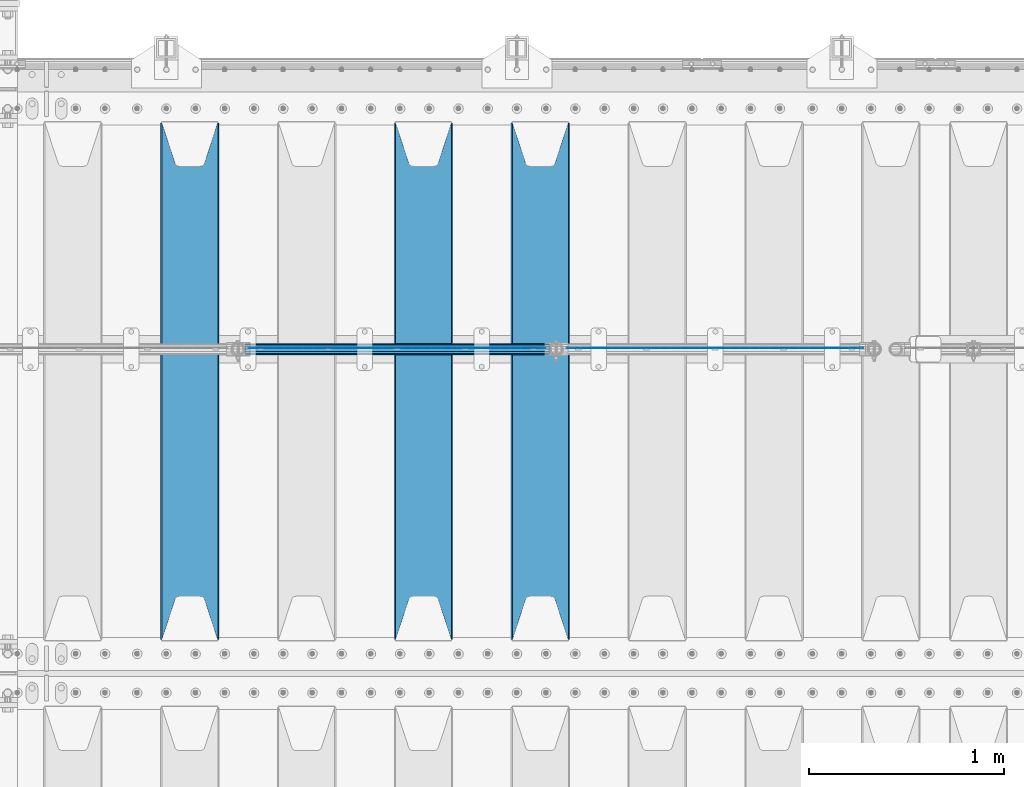
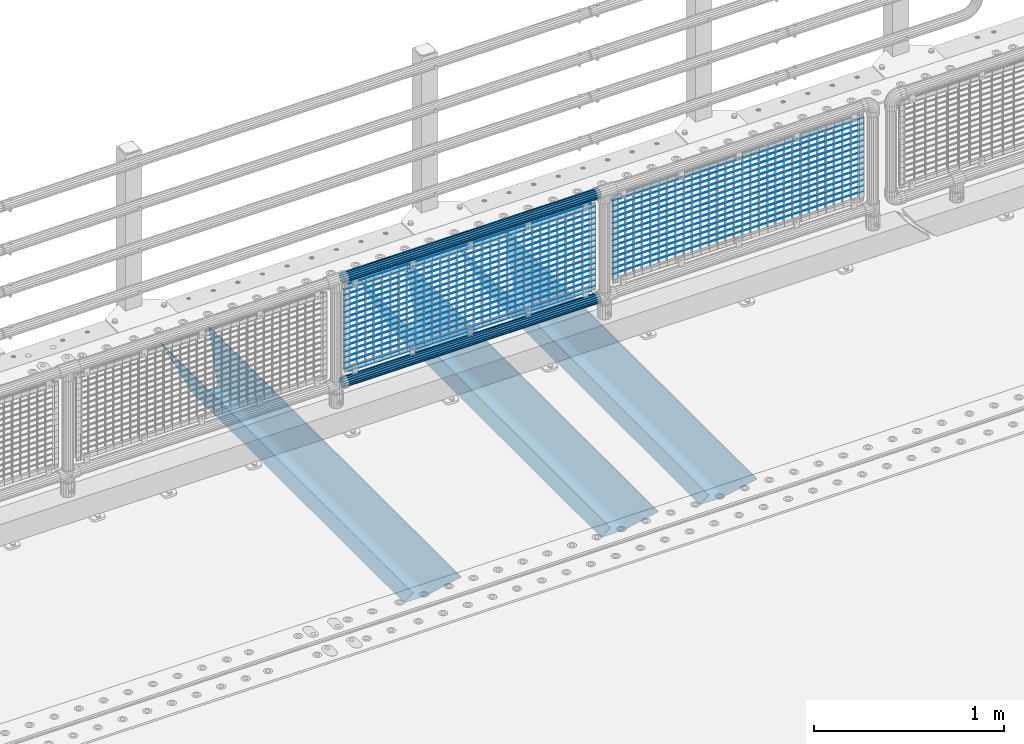
# One storey, part 133 of 242: 36 beams.
"""IFC2X3 building model written with IfcOpenShell, lengths in millimetres."""

from ifc_helpers import new_model, si_unit, frame, origin_with_axes, place, context, subcontext, project, spatial, faceted_brep, material, type_object, element, save


model = new_model("IFC2X3")

# Units and contexts
model_context = context("Model", 3, precision=1e-05, world=origin_with_axes())
body_context = subcontext(model_context, "Body", "Model", "MODEL_VIEW")
ifc_project = project(units=[si_unit("LENGTHUNIT", "METRE", prefix="MILLI"), si_unit("AREAUNIT", "SQUARE_METRE"), si_unit("VOLUMEUNIT", "CUBIC_METRE"), si_unit("MASSUNIT", "GRAM", prefix="KILO"), si_unit("TIMEUNIT", "SECOND"), si_unit("PLANEANGLEUNIT", "RADIAN"), si_unit("SOLIDANGLEUNIT", "STERADIAN"), si_unit("THERMODYNAMICTEMPERATUREUNIT", "DEGREE_CELSIUS"), si_unit("LUMINOUSINTENSITYUNIT", "LUMEN")], contexts=[model_context])

# Site, building, storey
site_placement = place(None, origin_with_axes())
site = spatial("IfcSite", under=ifc_project, at=site_placement, CompositionType="ELEMENT")
building_placement = place(site_placement, origin_with_axes())
building = spatial("IfcBuilding", under=site, at=building_placement, Name="Standard", CompositionType="ELEMENT")
storey_placement = place(building_placement, origin_with_axes())
storey = spatial("IfcBuildingStorey", under=building, at=storey_placement, Name="Undefined", CompositionType="ELEMENT", Elevation=0.0)

# Beams
ifc_material_1 = material(Name="Misc_Undefined")
beam_type_1 = type_object("IfcBeamType", Name="D3", PredefinedType="NOTDEFINED")
for number, where, z_axis, x_axis in (
    (1, (-25444.0, -19329.5, 851.596999999999), (0.0, 0.0, 1.0), (1.0, 0.0, 0.0)),
    (2, (-25444.0, -19329.5, 669.452), (0.0, 0.0, 1.0), (1.0, 0.0, 0.0)),
    (3, (-25444.0, -19329.5, 523.736), (0.0, 0.0, 1.0), (1.0, 0.0, 0.0)),
    (4, (-25444.0, -19329.5, 487.307), (0.0, 0.0, 1.0), (1.0, 0.0, 0.0)),
    (5, (-25444.0, -19329.5, 705.881), (0.0, 0.0, 1.0), (1.0, 0.0, 0.0)),
    (6, (-25444.0, -19329.5, 596.594), (0.0, 0.0, 1.0), (1.0, 0.0, 0.0)),
    (7, (-25444.0, -19329.5, 450.878), (0.0, 0.0, 1.0), (1.0, 0.0, 0.0)),
    (8, (-25444.0, -19329.5, 815.167999999999), (0.0, 0.0, 1.0), (1.0, 0.0, 0.0)),
    (9, (-25444.0, -19329.5, 888.025999999999), (0.0, 0.0, 1.0), (1.0, 0.0, 0.0)),
    (10, (-25444.0, -19329.5, 778.738999999999), (0.0, 0.0, 1.0), (1.0, 0.0, 0.0)),
    (11, (-25444.0, -19329.5, 742.309999999999), (0.0, 0.0, 1.0), (1.0, 0.0, 0.0)),
    (12, (-25444.0, -19329.5, 633.023), (0.0, 0.0, 1.0), (1.0, 0.0, 0.0)),
    (13, (-25444.0, -19329.5, 560.165), (0.0, 0.0, 1.0), (1.0, 0.0, 0.0)),
    (14, (-25444.0, -19329.5, 414.449), (0.0, 0.0, 1.0), (1.0, 0.0, 0.0)),
    (15, (-27077.0, -19329.5, 851.596999999999), (0.0, 0.0, 1.0), (1.0, 0.0, 0.0)),
    (16, (-27077.0, -19329.5, 669.452), (0.0, 0.0, 1.0), (1.0, 0.0, 0.0)),
    (17, (-27077.0, -19329.5, 523.736), (0.0, 0.0, 1.0), (1.0, 0.0, 0.0)),
    (18, (-27077.0, -19329.5, 487.307), (0.0, 0.0, 1.0), (1.0, 0.0, 0.0)),
    (19, (-27077.0, -19329.5, 705.881), (0.0, 0.0, 1.0), (1.0, 0.0, 0.0)),
    (20, (-27077.0, -19329.5, 596.594), (0.0, 0.0, 1.0), (1.0, 0.0, 0.0)),
    (21, (-27077.0, -19329.5, 450.878), (0.0, 0.0, 1.0), (1.0, 0.0, 0.0)),
    (22, (-27077.0, -19329.5, 815.167999999999), (0.0, 0.0, 1.0), (1.0, 0.0, 0.0)),
    (23, (-27077.0, -19329.5, 888.025999999999), (0.0, 0.0, 1.0), (1.0, 0.0, 0.0)),
    (24, (-27077.0, -19329.5, 778.738999999999), (0.0, 0.0, 1.0), (1.0, 0.0, 0.0)),
    (25, (-27077.0, -19329.5, 742.309999999999), (0.0, 0.0, 1.0), (1.0, 0.0, 0.0)),
    (26, (-27077.0, -19329.5, 633.023), (0.0, 0.0, 1.0), (1.0, 0.0, 0.0)),
    (27, (-27077.0, -19329.5, 560.165), (0.0, 0.0, 1.0), (1.0, 0.0, 0.0)),
    (28, (-27077.0, -19329.5, 414.449), (0.0, 0.0, 1.0), (1.0, 0.0, 0.0)),
):
    element("IfcBeam", number, at=place(storey_placement, frame(where, z_axis=z_axis, x_axis=x_axis)), inside=storey, type_object=beam_type_1, material=ifc_material_1, ObjectType="D3", context=body_context, shape_type="Brep", body=[
        faceted_brep([(0.0, -1.50000000000364, 0.0), (-3.63797880709171e-12, -0.750000000003638, -1.29903810567669), (1523.0, -0.75, -1.29903810567669), (1523.0, -1.5, 0.0), (0.0, 0.749999999996362, -1.29903810567669), (1523.0, 0.75, -1.29903810567669), (-3.63797880709171e-12, 1.49999999999636, 0.0), (1523.0, 1.5, 0.0), (0.0, 0.749999999996362, 1.29903810567669), (1523.0, 0.75, 1.29903810567669), (-3.63797880709171e-12, -0.750000000003638, 1.29903810567669), (1523.0, -0.75, 1.29903810567669)], [[[0, 1, 2, 3]], [[1, 4, 5, 2]], [[4, 6, 7, 5]], [[6, 8, 9, 7]], [[8, 10, 11, 9]], [[10, 0, 3, 11]], [[5, 7, 9, 11, 3, 2]], [[10, 8, 6, 4, 1, 0]]]),
    ])
beam_1_placement = place(storey_placement, frame((-27052.0, -19329.5, 353.02), z_axis=(0.0, 0.0, 1.0), x_axis=(1.0, 0.0, 0.0)))
element("IfcBeam", 29, at=beam_1_placement, inside=storey, type_object=beam_type_1, material=ifc_material_1, ObjectType="D3", context=body_context, shape_type="Brep", body=[
    faceted_brep([(0.0, -1.50000000000364, 0.0), (-3.63797880709171e-12, -0.750000000003638, -1.29903810567669), (1473.0, -0.75, -1.29903810567669), (1473.0, -1.5, 0.0), (0.0, 0.749999999996362, -1.29903810567669), (1473.0, 0.75, -1.29903810567663), (-3.63797880709171e-12, 1.49999999999636, 0.0), (1473.0, 1.5, 0.0), (0.0, 0.749999999996362, 1.29903810567669), (1473.0, 0.75, 1.29903810567669), (-3.63797880709171e-12, -0.750000000003638, 1.29903810567669), (1473.0, -0.75, 1.29903810567669)], [[[0, 1, 2, 3]], [[1, 4, 5, 2]], [[4, 6, 7, 5]], [[6, 8, 9, 7]], [[8, 10, 11, 9]], [[10, 0, 3, 11]], [[5, 7, 9, 11, 3, 2]], [[10, 8, 6, 4, 1, 0]]]),
])
beam_2_placement = place(storey_placement, frame((-27077.0, -19329.5, 378.02), z_axis=(0.0, 0.0, 1.0), x_axis=(1.0, 0.0, 0.0)))
element("IfcBeam", 30, at=beam_2_placement, inside=storey, type_object=beam_type_1, material=ifc_material_1, ObjectType="D3", context=body_context, shape_type="Brep", body=[
    faceted_brep([(0.0, -1.50000000000364, 0.0), (-3.63797880709171e-12, -0.750000000003638, -1.29903810567669), (1523.0, -0.75, -1.29903810567669), (1523.0, -1.5, 0.0), (0.0, 0.749999999996362, -1.29903810567669), (1523.0, 0.75, -1.29903810567669), (-3.63797880709171e-12, 1.49999999999636, 0.0), (1523.0, 1.5, 0.0), (0.0, 0.749999999996362, 1.29903810567669), (1523.0, 0.75, 1.29903810567669), (-3.63797880709171e-12, -0.750000000003638, 1.29903810567669), (1523.0, -0.75, 1.29903810567669)], [[[0, 1, 2, 3]], [[1, 4, 5, 2]], [[4, 6, 7, 5]], [[6, 8, 9, 7]], [[8, 10, 11, 9]], [[10, 0, 3, 11]], [[5, 7, 9, 11, 3, 2]], [[10, 8, 6, 4, 1, 0]]]),
])
beam_3_placement = place(storey_placement, frame((-27052.0, -19329.5, 913.02), z_axis=(0.0, 0.0, 1.0), x_axis=(1.0, 0.0, 0.0)))
element("IfcBeam", 31, at=beam_3_placement, inside=storey, type_object=beam_type_1, material=ifc_material_1, ObjectType="D3", context=body_context, shape_type="Brep", body=[
    faceted_brep([(0.0, -1.50000000000364, 0.0), (-3.63797880709171e-12, -0.750000000003638, -1.29903810567669), (1473.0, -0.75, -1.29903810567669), (1473.0, -1.5, 0.0), (0.0, 0.749999999996362, -1.29903810567669), (1473.0, 0.75, -1.29903810567663), (-3.63797880709171e-12, 1.49999999999636, 0.0), (1473.0, 1.5, 0.0), (0.0, 0.749999999996362, 1.29903810567669), (1473.0, 0.75, 1.29903810567669), (-3.63797880709171e-12, -0.750000000003638, 1.29903810567669), (1473.0, -0.75, 1.29903810567669)], [[[0, 1, 2, 3]], [[1, 4, 5, 2]], [[4, 6, 7, 5]], [[6, 8, 9, 7]], [[8, 10, 11, 9]], [[10, 0, 3, 11]], [[5, 7, 9, 11, 3, 2]], [[10, 8, 6, 4, 1, 0]]]),
])
ifc_material_2 = material()
beam_type_2 = type_object("IfcBeamType", PredefinedType="NOTDEFINED")
beam_4_placement = place(storey_placement, frame((-27097.15, -19335.5, 969.849999999999), z_axis=(0.0, 0.0, 1.0), x_axis=(1.0, 0.0, 0.0)))
element("IfcBeam", 32, at=beam_4_placement, inside=storey, type_object=beam_type_2, material=ifc_material_2, context=body_context, shape_type="Brep", body=[
    faceted_brep([(0.0, -25.3499999999985, 0.0), (0.0, -23.4203461491597, 9.70102501045403), (1563.0, -23.4203461491597, 9.70102501045506), (1563.0, -25.3499999999985, 0.0), (0.0, -17.9251569030785, 17.9251569030785), (1563.0, -17.9251569030785, 17.925156903079), (0.0, -9.70102501045403, 23.4203461491597), (1563.0, -9.70102501045403, 23.4203461491611), (0.0, 0.0, 25.3499999999985), (1563.0, 0.0, 25.35), (0.0, 9.70102501045403, 23.4203461491597), (1563.0, 9.70102501045403, 23.4203461491611), (0.0, 17.9251569030785, 17.9251569030785), (1563.0, 17.9251569030785, 17.925156903079), (0.0, 23.4203461491597, 9.70102501045403), (1563.0, 23.4203461491597, 9.70102501045506), (0.0, 25.3499999999985, 0.0), (1563.0, 25.3499999999985, 0.0), (0.0, 23.4203461491597, -9.70102501045403), (1563.0, 23.4203461491597, -9.70102501045506), (0.0, 17.9251569030785, -17.9251569030785), (1563.0, 17.9251569030785, -17.925156903079), (0.0, 9.70102501045403, -23.4203461491597), (1563.0, 9.70102501045403, -23.4203461491611), (0.0, 0.0, -25.3499999999985), (1563.0, 0.0, -25.35), (0.0, -9.70102501045403, -23.4203461491597), (1563.0, -9.70102501045403, -23.4203461491611), (0.0, -17.9251569030785, -17.9251569030785), (1563.0, -17.9251569030785, -17.925156903079), (0.0, -23.4203461491597, -9.70102501045403), (1563.0, -23.4203461491597, -9.70102501045506), (0.0, -30.1500000000015, 0.0), (0.0, -27.8549679052157, -11.5379054858058), (1563.0, -27.8549679052157, -11.5379054858075), (1563.0, -30.1500000000015, 0.0), (0.0, -21.3192694527752, -21.3192694527752), (1563.0, -21.3192694527752, -21.3192694527744), (0.0, -11.5379054858058, -27.8549679052157), (1563.0, -11.5379054858058, -27.8549679052153), (0.0, 0.0, -30.1500000000015), (1563.0, 0.0, -30.15), (0.0, 11.5379054858058, -27.8549679052157), (1563.0, 11.5379054858058, -27.8549679052153), (0.0, 21.3192694527752, -21.3192694527752), (1563.0, 21.3192694527752, -21.3192694527744), (0.0, 27.8549679052157, -11.5379054858058), (1563.0, 27.8549679052157, -11.5379054858074), (0.0, 30.1500000000015, 0.0), (1563.0, 30.1500000000015, 0.0), (0.0, 27.8549679052157, 11.5379054858058), (1563.0, 27.8549679052157, 11.5379054858074), (0.0, 21.3192694527752, 21.3192694527752), (1563.0, 21.3192694527752, 21.3192694527744), (0.0, 11.5379054858058, 27.8549679052157), (1563.0, 11.5379054858058, 27.8549679052153), (0.0, 0.0, 30.1500000000015), (1563.0, 0.0, 30.15), (0.0, -11.5379054858058, 27.8549679052157), (1563.0, -11.5379054858058, 27.8549679052153), (0.0, -21.3192694527752, 21.3192694527752), (1563.0, -21.3192694527752, 21.3192694527744), (0.0, -27.8549679052157, 11.5379054858058), (1563.0, -27.8549679052157, 11.5379054858074)], [[[0, 1, 2, 3]], [[1, 4, 5, 2]], [[4, 6, 7, 5]], [[6, 8, 9, 7]], [[8, 10, 11, 9]], [[10, 12, 13, 11]], [[12, 14, 15, 13]], [[14, 16, 17, 15]], [[16, 18, 19, 17]], [[18, 20, 21, 19]], [[20, 22, 23, 21]], [[22, 24, 25, 23]], [[24, 26, 27, 25]], [[26, 28, 29, 27]], [[28, 30, 31, 29]], [[30, 0, 3, 31]], [[32, 33, 34, 35]], [[33, 36, 37, 34]], [[36, 38, 39, 37]], [[38, 40, 41, 39]], [[40, 42, 43, 41]], [[42, 44, 45, 43]], [[44, 46, 47, 45]], [[46, 48, 49, 47]], [[48, 50, 51, 49]], [[50, 52, 53, 51]], [[52, 54, 55, 53]], [[54, 56, 57, 55]], [[56, 58, 59, 57]], [[58, 60, 61, 59]], [[60, 62, 63, 61]], [[62, 32, 35, 63]], [[37, 39, 41, 43, 45, 47, 49, 51, 53, 55, 57, 59, 61, 63, 35, 34], [5, 7, 9, 11, 13, 15, 17, 19, 21, 23, 25, 27, 29, 31, 3, 2]], [[62, 60, 58, 56, 54, 52, 50, 48, 46, 44, 42, 40, 38, 36, 33, 32], [30, 28, 26, 24, 22, 20, 18, 16, 14, 12, 10, 8, 6, 4, 1, 0]]]),
])
beam_5_placement = place(storey_placement, frame((-27097.15, -19335.5, 298.170000000001), z_axis=(0.0, 0.0, 1.0), x_axis=(1.0, 0.0, 0.0)))
element("IfcBeam", 33, at=beam_5_placement, inside=storey, type_object=beam_type_2, material=ifc_material_2, context=body_context, shape_type="Brep", body=[
    faceted_brep([(0.0, -25.3499999999985, 0.0), (0.0, -23.4203461491597, 9.70102501045403), (1563.0, -23.4203461491597, 9.70102501045506), (1563.0, -25.3499999999985, 0.0), (0.0, -17.9251569030785, 17.9251569030785), (1563.0, -17.9251569030785, 17.925156903079), (0.0, -9.70102501045403, 23.4203461491597), (1563.0, -9.70102501045403, 23.4203461491611), (0.0, 0.0, 25.3499999999985), (1563.0, 0.0, 25.35), (0.0, 9.70102501045403, 23.4203461491597), (1563.0, 9.70102501045403, 23.4203461491611), (0.0, 17.9251569030785, 17.9251569030785), (1563.0, 17.9251569030785, 17.925156903079), (0.0, 23.4203461491597, 9.70102501045403), (1563.0, 23.4203461491597, 9.70102501045506), (0.0, 25.3499999999985, 0.0), (1563.0, 25.3499999999985, 0.0), (0.0, 23.4203461491597, -9.70102501045403), (1563.0, 23.4203461491597, -9.70102501045506), (0.0, 17.9251569030785, -17.9251569030785), (1563.0, 17.9251569030785, -17.925156903079), (0.0, 9.70102501045403, -23.4203461491597), (1563.0, 9.70102501045403, -23.4203461491611), (0.0, 0.0, -25.3499999999985), (1563.0, 0.0, -25.35), (0.0, -9.70102501045403, -23.4203461491597), (1563.0, -9.70102501045403, -23.4203461491611), (0.0, -17.9251569030785, -17.9251569030785), (1563.0, -17.9251569030785, -17.925156903079), (0.0, -23.4203461491597, -9.70102501045403), (1563.0, -23.4203461491597, -9.70102501045506), (0.0, -30.1500000000015, 0.0), (0.0, -27.8549679052157, -11.5379054858058), (1563.0, -27.8549679052157, -11.5379054858075), (1563.0, -30.1500000000015, 0.0), (0.0, -21.3192694527752, -21.3192694527752), (1563.0, -21.3192694527752, -21.3192694527744), (0.0, -11.5379054858058, -27.8549679052157), (1563.0, -11.5379054858058, -27.8549679052153), (0.0, 0.0, -30.1500000000015), (1563.0, 0.0, -30.15), (0.0, 11.5379054858058, -27.8549679052157), (1563.0, 11.5379054858058, -27.8549679052153), (0.0, 21.3192694527752, -21.3192694527752), (1563.0, 21.3192694527752, -21.3192694527744), (0.0, 27.8549679052157, -11.5379054858058), (1563.0, 27.8549679052157, -11.5379054858074), (0.0, 30.1500000000015, 0.0), (1563.0, 30.1500000000015, 0.0), (0.0, 27.8549679052157, 11.5379054858058), (1563.0, 27.8549679052157, 11.5379054858074), (0.0, 21.3192694527752, 21.3192694527752), (1563.0, 21.3192694527752, 21.3192694527744), (0.0, 11.5379054858058, 27.8549679052157), (1563.0, 11.5379054858058, 27.8549679052153), (0.0, 0.0, 30.1500000000015), (1563.0, 0.0, 30.15), (0.0, -11.5379054858058, 27.8549679052157), (1563.0, -11.5379054858058, 27.8549679052153), (0.0, -21.3192694527752, 21.3192694527752), (1563.0, -21.3192694527752, 21.3192694527744), (0.0, -27.8549679052157, 11.5379054858058), (1563.0, -27.8549679052157, 11.5379054858074)], [[[0, 1, 2, 3]], [[1, 4, 5, 2]], [[4, 6, 7, 5]], [[6, 8, 9, 7]], [[8, 10, 11, 9]], [[10, 12, 13, 11]], [[12, 14, 15, 13]], [[14, 16, 17, 15]], [[16, 18, 19, 17]], [[18, 20, 21, 19]], [[20, 22, 23, 21]], [[22, 24, 25, 23]], [[24, 26, 27, 25]], [[26, 28, 29, 27]], [[28, 30, 31, 29]], [[30, 0, 3, 31]], [[32, 33, 34, 35]], [[33, 36, 37, 34]], [[36, 38, 39, 37]], [[38, 40, 41, 39]], [[40, 42, 43, 41]], [[42, 44, 45, 43]], [[44, 46, 47, 45]], [[46, 48, 49, 47]], [[48, 50, 51, 49]], [[50, 52, 53, 51]], [[52, 54, 55, 53]], [[54, 56, 57, 55]], [[56, 58, 59, 57]], [[58, 60, 61, 59]], [[60, 62, 63, 61]], [[62, 32, 35, 63]], [[37, 39, 41, 43, 45, 47, 49, 51, 53, 55, 57, 59, 61, 63, 35, 34], [5, 7, 9, 11, 13, 15, 17, 19, 21, 23, 25, 27, 29, 31, 3, 2]], [[62, 60, 58, 56, 54, 52, 50, 48, 46, 44, 42, 40, 38, 36, 33, 32], [30, 28, 26, 24, 22, 20, 18, 16, 14, 12, 10, 8, 6, 4, 1, 0]]]),
])
ifc_material_3 = material(Name="STEEL/S355N")
beam_type_3 = type_object("IfcBeamType", PredefinedType="NOTDEFINED")
beam_6_placement = place(storey_placement, frame((-25580.0, -20825.0, -115.0), z_axis=(0.0, 0.0, 1.0), x_axis=(0.0, 1.0, 0.0)))
element("IfcBeam", 34, at=beam_6_placement, inside=storey, type_object=beam_type_3, material=ifc_material_3, context=body_context, shape_type="Brep", body=[
    faceted_brep([(0.0, 150.0, 115.0), (0.0, 143.689999999999, 115.0), (2650.00000000297, 143.689999999999, 115.0), (2650.00000000297, 150.0, 115.0), (2650.00000000297, 142.059565218402, 110.000000003099), (2650.00000000297, 148.369565218403, 110.000000003099), (2441.90079219209, -80.1103600731112, -98.0992078077845), (2437.7588105432, -77.5672621345584, -102.241189456673), (2434.06523489747, -74.4080125315522, -105.934765102404), (2430.91086095089, -70.710272125576, -109.089139048974), (2428.37322971128, -66.5649389910068, -111.626770288588), (2426.51472138055, -62.0739139532889, -113.485278619323), (2425.38102192092, -57.3475956567672, -114.618978078955), (2424.99999999987, -52.5021667386536, -115.0), (2424.99999999987, 52.5021667386536, -115.0), (2425.38102192092, 57.3475956567672, -114.618978078955), (2426.51472138055, 62.0739139532889, -113.485278619323), (2428.37322971128, 66.5649389910068, -111.626770288588), (2430.91086095089, 70.710272125576, -109.089139048974), (2434.06523489747, 74.4080125315522, -105.934765102404), (2437.7588105432, 77.5672621345584, -102.241189456673), (2441.90079219209, 80.1103600731112, -98.0992078077846), (2446.38936140511, 81.9747917625791, -93.6106385947584), (2448.2494850041, 76.2713538057251, -91.7505149957729), (2444.62967112262, 74.76777986261, -95.3703288772456), (2441.28936334126, 72.7168944282894, -98.710636658607), (2438.31067330438, 70.1691124903846, -101.689326695487), (2435.76682334747, 67.1870637758839, -104.233176652398), (2433.72034654133, 63.8440531834895, -106.279653458539), (2432.22154950042, 60.222258798236, -107.778450499454), (2431.30727574265, 56.4107117849089, -108.692724257221), (2430.99999999987, 52.5031078186876, -109.0), (2430.99999999987, -52.5031078186876, -109.0), (2431.30727574265, -56.4107117849089, -108.692724257221), (2432.22154950042, -60.222258798236, -107.778450499454), (2433.72034654133, -63.8440531834895, -106.279653458539), (2435.76682334747, -67.1870637758839, -104.233176652398), (2438.31067330438, -70.1691124903846, -101.689326695487), (2441.28936334126, -72.7168944282894, -98.7106366586071), (2444.62967112262, -74.76777986261, -95.3703288772457), (2448.2494850041, -76.2713538057251, -91.7505149957729), (2650.00000000297, -142.059565218402, 110.000000003099), (2650.00000000297, -148.369565218403, 110.000000003099), (2446.38936140511, -81.9747917625791, -93.6106385947584), (2650.00000000297, -143.689999999999, 115.0), (2650.00000000297, -150.0, 115.0), (0.0, -143.689999999999, 115.0), (0.0, -150.0, 115.0), (0.0, -148.369565218261, 110.000000002669), (203.610638597427, -81.9747917625791, -93.6106385947584), (208.099207810454, -80.1103600731112, -98.0992078077845), (212.241189459342, -77.5672621345584, -102.241189456673), (215.934765105074, -74.4080125315522, -105.934765102404), (219.089139051644, -70.710272125576, -109.089139048974), (221.626770291256, -66.5649389910068, -111.626770288588), (223.485278621993, -62.0739139532889, -113.485278619323), (224.618978081624, -57.3475956567672, -114.618978078955), (225.00000000267, -52.5021667386536, -115.0), (225.00000000267, 52.5021667386536, -115.0), (224.618978081624, 57.3475956567672, -114.618978078955), (223.485278621993, 62.0739139532889, -113.485278619323), (221.626770291256, 66.5649389910068, -111.626770288588), (219.089139051644, 70.710272125576, -109.089139048974), (215.934765105074, 74.4080125315522, -105.934765102404), (212.241189459342, 77.5672621345584, -102.241189456673), (208.099207810454, 80.1103600731112, -98.0992078077846), (203.610638597427, 81.9747917625791, -93.6106385947584), (0.0, 148.369565218261, 110.000000002669), (0.0, 142.05956521826, 110.000000002669), (201.750514998443, 76.2713538057251, -91.7505149957729), (205.370328879915, 74.76777986261, -95.3703288772456), (208.710636661275, 72.7168944282894, -98.710636658607), (211.689326698157, 70.1691124903846, -101.689326695487), (214.233176655067, 67.1870637758839, -104.233176652398), (216.279653461206, 63.8440531834895, -106.279653458539), (217.778450502123, 60.222258798236, -107.778450499454), (218.69272425989, 56.4107117849089, -108.692724257221), (219.00000000267, 52.5031078186876, -109.0), (219.00000000267, -52.5031078186876, -109.0), (218.69272425989, -56.4107117849089, -108.692724257221), (217.778450502123, -60.222258798236, -107.778450499454), (216.279653461206, -63.8440531834895, -106.279653458539), (214.233176655067, -67.1870637758839, -104.233176652398), (211.689326698157, -70.1691124903846, -101.689326695487), (208.710636661275, -72.7168944282894, -98.7106366586071), (205.370328879915, -74.76777986261, -95.3703288772457), (201.750514998443, -76.2713538057251, -91.7505149957729), (0.0, -142.05956521826, 110.000000002669)], [[[0, 1, 2, 3]], [[3, 2, 4, 5]], [[6, 7, 8, 9, 10, 11, 12, 13, 14, 15, 16, 17, 18, 19, 20, 21, 22, 5, 4, 23, 24, 25, 26, 27, 28, 29, 30, 31, 32, 33, 34, 35, 36, 37, 38, 39, 40, 41, 42, 43]], [[44, 45, 42, 41]], [[46, 47, 45, 44]], [[43, 42, 45, 47, 48, 49]], [[6, 43, 49, 50]], [[7, 6, 50, 51]], [[8, 7, 51, 52]], [[9, 8, 52, 53]], [[10, 9, 53, 54]], [[11, 10, 54, 55]], [[12, 11, 55, 56]], [[13, 12, 56, 57]], [[14, 13, 57, 58]], [[15, 14, 58, 59]], [[16, 15, 59, 60]], [[17, 16, 60, 61]], [[18, 17, 61, 62]], [[19, 18, 62, 63]], [[20, 19, 63, 64]], [[21, 20, 64, 65]], [[22, 21, 65, 66]], [[0, 3, 5, 22, 66, 67]], [[1, 0, 67, 68]], [[23, 4, 2, 1, 68, 69]], [[24, 23, 69, 70]], [[25, 24, 70, 71]], [[26, 25, 71, 72]], [[27, 26, 72, 73]], [[28, 27, 73, 74]], [[29, 28, 74, 75]], [[30, 29, 75, 76]], [[31, 30, 76, 77]], [[32, 31, 77, 78]], [[33, 32, 78, 79]], [[34, 33, 79, 80]], [[35, 34, 80, 81]], [[36, 35, 81, 82]], [[37, 36, 82, 83]], [[38, 37, 83, 84]], [[39, 38, 84, 85]], [[40, 39, 85, 86]], [[46, 44, 41, 40, 86, 87]], [[47, 46, 87, 48]], [[86, 85, 84, 83, 82, 81, 80, 79, 78, 77, 76, 75, 74, 73, 72, 71, 70, 69, 68, 67, 66, 65, 64, 63, 62, 61, 60, 59, 58, 57, 56, 55, 54, 53, 52, 51, 50, 49, 48, 87]]]),
])
beam_7_placement = place(storey_placement, frame((-26180.0, -20825.0, -115.0), z_axis=(0.0, 0.0, 1.0), x_axis=(0.0, 1.0, 0.0)))
element("IfcBeam", 35, at=beam_7_placement, inside=storey, type_object=beam_type_3, material=ifc_material_3, context=body_context, shape_type="Brep", body=[
    faceted_brep([(0.0, 150.0, 115.0), (0.0, 143.689999999999, 115.0), (2650.00000000297, 143.689999999999, 115.0), (2650.00000000297, 150.0, 115.0), (2650.00000000297, 142.059565218402, 110.000000003099), (2650.00000000297, 148.369565218403, 110.000000003099), (2441.90079219209, -80.1103600731112, -98.0992078077845), (2437.7588105432, -77.5672621345584, -102.241189456673), (2434.06523489747, -74.4080125315522, -105.934765102404), (2430.91086095089, -70.710272125576, -109.089139048974), (2428.37322971128, -66.5649389910068, -111.626770288588), (2426.51472138055, -62.0739139532889, -113.485278619323), (2425.38102192092, -57.3475956567672, -114.618978078955), (2424.99999999987, -52.5021667386536, -115.0), (2424.99999999987, 52.5021667386536, -115.0), (2425.38102192092, 57.3475956567672, -114.618978078955), (2426.51472138055, 62.0739139532889, -113.485278619323), (2428.37322971128, 66.5649389910068, -111.626770288588), (2430.91086095089, 70.710272125576, -109.089139048974), (2434.06523489747, 74.4080125315522, -105.934765102404), (2437.7588105432, 77.5672621345584, -102.241189456673), (2441.90079219209, 80.1103600731112, -98.0992078077846), (2446.38936140511, 81.9747917625791, -93.6106385947584), (2448.2494850041, 76.2713538057251, -91.7505149957729), (2444.62967112262, 74.76777986261, -95.3703288772456), (2441.28936334126, 72.7168944282894, -98.710636658607), (2438.31067330438, 70.1691124903846, -101.689326695487), (2435.76682334747, 67.1870637758839, -104.233176652398), (2433.72034654133, 63.8440531834895, -106.279653458539), (2432.22154950042, 60.222258798236, -107.778450499454), (2431.30727574265, 56.4107117849089, -108.692724257221), (2430.99999999987, 52.5031078186876, -109.0), (2430.99999999987, -52.5031078186876, -109.0), (2431.30727574265, -56.4107117849089, -108.692724257221), (2432.22154950042, -60.222258798236, -107.778450499454), (2433.72034654133, -63.8440531834895, -106.279653458539), (2435.76682334747, -67.1870637758839, -104.233176652398), (2438.31067330438, -70.1691124903846, -101.689326695487), (2441.28936334126, -72.7168944282894, -98.7106366586071), (2444.62967112262, -74.76777986261, -95.3703288772457), (2448.2494850041, -76.2713538057251, -91.7505149957729), (2650.00000000297, -142.059565218402, 110.000000003099), (2650.00000000297, -148.369565218403, 110.000000003099), (2446.38936140511, -81.9747917625791, -93.6106385947584), (2650.00000000297, -143.689999999999, 115.0), (2650.00000000297, -150.0, 115.0), (0.0, -143.689999999999, 115.0), (0.0, -150.0, 115.0), (0.0, -148.369565218261, 110.000000002669), (203.610638597427, -81.9747917625791, -93.6106385947584), (208.099207810454, -80.1103600731112, -98.0992078077845), (212.241189459342, -77.5672621345584, -102.241189456673), (215.934765105074, -74.4080125315522, -105.934765102404), (219.089139051644, -70.710272125576, -109.089139048974), (221.626770291256, -66.5649389910068, -111.626770288588), (223.485278621993, -62.0739139532889, -113.485278619323), (224.618978081624, -57.3475956567672, -114.618978078955), (225.00000000267, -52.5021667386536, -115.0), (225.00000000267, 52.5021667386536, -115.0), (224.618978081624, 57.3475956567672, -114.618978078955), (223.485278621993, 62.0739139532889, -113.485278619323), (221.626770291256, 66.5649389910068, -111.626770288588), (219.089139051644, 70.710272125576, -109.089139048974), (215.934765105074, 74.4080125315522, -105.934765102404), (212.241189459342, 77.5672621345584, -102.241189456673), (208.099207810454, 80.1103600731112, -98.0992078077846), (203.610638597427, 81.9747917625791, -93.6106385947584), (0.0, 148.369565218261, 110.000000002669), (0.0, 142.05956521826, 110.000000002669), (201.750514998443, 76.2713538057251, -91.7505149957729), (205.370328879915, 74.76777986261, -95.3703288772456), (208.710636661275, 72.7168944282894, -98.710636658607), (211.689326698157, 70.1691124903846, -101.689326695487), (214.233176655067, 67.1870637758839, -104.233176652398), (216.279653461206, 63.8440531834895, -106.279653458539), (217.778450502123, 60.222258798236, -107.778450499454), (218.69272425989, 56.4107117849089, -108.692724257221), (219.00000000267, 52.5031078186876, -109.0), (219.00000000267, -52.5031078186876, -109.0), (218.69272425989, -56.4107117849089, -108.692724257221), (217.778450502123, -60.222258798236, -107.778450499454), (216.279653461206, -63.8440531834895, -106.279653458539), (214.233176655067, -67.1870637758839, -104.233176652398), (211.689326698157, -70.1691124903846, -101.689326695487), (208.710636661275, -72.7168944282894, -98.7106366586071), (205.370328879915, -74.76777986261, -95.3703288772457), (201.750514998443, -76.2713538057251, -91.7505149957729), (0.0, -142.05956521826, 110.000000002669)], [[[0, 1, 2, 3]], [[3, 2, 4, 5]], [[6, 7, 8, 9, 10, 11, 12, 13, 14, 15, 16, 17, 18, 19, 20, 21, 22, 5, 4, 23, 24, 25, 26, 27, 28, 29, 30, 31, 32, 33, 34, 35, 36, 37, 38, 39, 40, 41, 42, 43]], [[44, 45, 42, 41]], [[46, 47, 45, 44]], [[43, 42, 45, 47, 48, 49]], [[6, 43, 49, 50]], [[7, 6, 50, 51]], [[8, 7, 51, 52]], [[9, 8, 52, 53]], [[10, 9, 53, 54]], [[11, 10, 54, 55]], [[12, 11, 55, 56]], [[13, 12, 56, 57]], [[14, 13, 57, 58]], [[15, 14, 58, 59]], [[16, 15, 59, 60]], [[17, 16, 60, 61]], [[18, 17, 61, 62]], [[19, 18, 62, 63]], [[20, 19, 63, 64]], [[21, 20, 64, 65]], [[22, 21, 65, 66]], [[0, 3, 5, 22, 66, 67]], [[1, 0, 67, 68]], [[23, 4, 2, 1, 68, 69]], [[24, 23, 69, 70]], [[25, 24, 70, 71]], [[26, 25, 71, 72]], [[27, 26, 72, 73]], [[28, 27, 73, 74]], [[29, 28, 74, 75]], [[30, 29, 75, 76]], [[31, 30, 76, 77]], [[32, 31, 77, 78]], [[33, 32, 78, 79]], [[34, 33, 79, 80]], [[35, 34, 80, 81]], [[36, 35, 81, 82]], [[37, 36, 82, 83]], [[38, 37, 83, 84]], [[39, 38, 84, 85]], [[40, 39, 85, 86]], [[46, 44, 41, 40, 86, 87]], [[47, 46, 87, 48]], [[86, 85, 84, 83, 82, 81, 80, 79, 78, 77, 76, 75, 74, 73, 72, 71, 70, 69, 68, 67, 66, 65, 64, 63, 62, 61, 60, 59, 58, 57, 56, 55, 54, 53, 52, 51, 50, 49, 48, 87]]]),
])
beam_8_placement = place(storey_placement, frame((-27380.0, -20825.0, -115.0), z_axis=(0.0, 0.0, 1.0), x_axis=(0.0, 1.0, 0.0)))
element("IfcBeam", 36, at=beam_8_placement, inside=storey, type_object=beam_type_3, material=ifc_material_3, context=body_context, shape_type="Brep", body=[
    faceted_brep([(0.0, 150.0, 115.0), (0.0, 143.689999999999, 115.0), (2650.00000000297, 143.689999999999, 115.0), (2650.00000000297, 150.0, 115.0), (2650.00000000297, 142.059565218402, 110.000000003099), (2650.00000000297, 148.369565218403, 110.000000003099), (2441.90079219209, -80.1103600731112, -98.0992078077845), (2437.7588105432, -77.5672621345584, -102.241189456673), (2434.06523489747, -74.4080125315522, -105.934765102404), (2430.91086095089, -70.710272125576, -109.089139048974), (2428.37322971128, -66.5649389910068, -111.626770288588), (2426.51472138055, -62.0739139532889, -113.485278619323), (2425.38102192092, -57.3475956567672, -114.618978078955), (2424.99999999987, -52.5021667386536, -115.0), (2424.99999999987, 52.5021667386536, -115.0), (2425.38102192092, 57.3475956567672, -114.618978078955), (2426.51472138055, 62.0739139532889, -113.485278619323), (2428.37322971128, 66.5649389910068, -111.626770288588), (2430.91086095089, 70.710272125576, -109.089139048974), (2434.06523489747, 74.4080125315522, -105.934765102404), (2437.7588105432, 77.5672621345584, -102.241189456673), (2441.90079219209, 80.1103600731112, -98.0992078077846), (2446.38936140511, 81.9747917625791, -93.6106385947584), (2448.2494850041, 76.2713538057251, -91.7505149957729), (2444.62967112262, 74.76777986261, -95.3703288772456), (2441.28936334126, 72.7168944282894, -98.710636658607), (2438.31067330438, 70.1691124903846, -101.689326695487), (2435.76682334747, 67.1870637758839, -104.233176652398), (2433.72034654133, 63.8440531834895, -106.279653458539), (2432.22154950042, 60.222258798236, -107.778450499454), (2431.30727574265, 56.4107117849089, -108.692724257221), (2430.99999999987, 52.5031078186876, -109.0), (2430.99999999987, -52.5031078186876, -109.0), (2431.30727574265, -56.4107117849089, -108.692724257221), (2432.22154950042, -60.222258798236, -107.778450499454), (2433.72034654133, -63.8440531834895, -106.279653458539), (2435.76682334747, -67.1870637758839, -104.233176652398), (2438.31067330438, -70.1691124903846, -101.689326695487), (2441.28936334126, -72.7168944282894, -98.7106366586071), (2444.62967112262, -74.76777986261, -95.3703288772457), (2448.2494850041, -76.2713538057251, -91.7505149957729), (2650.00000000297, -142.059565218402, 110.000000003099), (2650.00000000297, -148.369565218403, 110.000000003099), (2446.38936140511, -81.9747917625791, -93.6106385947584), (2650.00000000297, -143.689999999999, 115.0), (2650.00000000297, -150.0, 115.0), (0.0, -143.689999999999, 115.0), (0.0, -150.0, 115.0), (0.0, -148.369565218261, 110.000000002669), (203.610638597427, -81.9747917625791, -93.6106385947584), (208.099207810454, -80.1103600731112, -98.0992078077845), (212.241189459342, -77.5672621345584, -102.241189456673), (215.934765105074, -74.4080125315522, -105.934765102404), (219.089139051644, -70.710272125576, -109.089139048974), (221.626770291256, -66.5649389910068, -111.626770288588), (223.485278621993, -62.0739139532889, -113.485278619323), (224.618978081624, -57.3475956567672, -114.618978078955), (225.00000000267, -52.5021667386536, -115.0), (225.00000000267, 52.5021667386536, -115.0), (224.618978081624, 57.3475956567672, -114.618978078955), (223.485278621993, 62.0739139532889, -113.485278619323), (221.626770291256, 66.5649389910068, -111.626770288588), (219.089139051644, 70.710272125576, -109.089139048974), (215.934765105074, 74.4080125315522, -105.934765102404), (212.241189459342, 77.5672621345584, -102.241189456673), (208.099207810454, 80.1103600731112, -98.0992078077846), (203.610638597427, 81.9747917625791, -93.6106385947584), (0.0, 148.369565218261, 110.000000002669), (0.0, 142.05956521826, 110.000000002669), (201.750514998443, 76.2713538057251, -91.7505149957729), (205.370328879915, 74.76777986261, -95.3703288772456), (208.710636661275, 72.7168944282894, -98.710636658607), (211.689326698157, 70.1691124903846, -101.689326695487), (214.233176655067, 67.1870637758839, -104.233176652398), (216.279653461206, 63.8440531834895, -106.279653458539), (217.778450502123, 60.222258798236, -107.778450499454), (218.69272425989, 56.4107117849089, -108.692724257221), (219.00000000267, 52.5031078186876, -109.0), (219.00000000267, -52.5031078186876, -109.0), (218.69272425989, -56.4107117849089, -108.692724257221), (217.778450502123, -60.222258798236, -107.778450499454), (216.279653461206, -63.8440531834895, -106.279653458539), (214.233176655067, -67.1870637758839, -104.233176652398), (211.689326698157, -70.1691124903846, -101.689326695487), (208.710636661275, -72.7168944282894, -98.7106366586071), (205.370328879915, -74.76777986261, -95.3703288772457), (201.750514998443, -76.2713538057251, -91.7505149957729), (0.0, -142.05956521826, 110.000000002669)], [[[0, 1, 2, 3]], [[3, 2, 4, 5]], [[6, 7, 8, 9, 10, 11, 12, 13, 14, 15, 16, 17, 18, 19, 20, 21, 22, 5, 4, 23, 24, 25, 26, 27, 28, 29, 30, 31, 32, 33, 34, 35, 36, 37, 38, 39, 40, 41, 42, 43]], [[44, 45, 42, 41]], [[46, 47, 45, 44]], [[43, 42, 45, 47, 48, 49]], [[6, 43, 49, 50]], [[7, 6, 50, 51]], [[8, 7, 51, 52]], [[9, 8, 52, 53]], [[10, 9, 53, 54]], [[11, 10, 54, 55]], [[12, 11, 55, 56]], [[13, 12, 56, 57]], [[14, 13, 57, 58]], [[15, 14, 58, 59]], [[16, 15, 59, 60]], [[17, 16, 60, 61]], [[18, 17, 61, 62]], [[19, 18, 62, 63]], [[20, 19, 63, 64]], [[21, 20, 64, 65]], [[22, 21, 65, 66]], [[0, 3, 5, 22, 66, 67]], [[1, 0, 67, 68]], [[23, 4, 2, 1, 68, 69]], [[24, 23, 69, 70]], [[25, 24, 70, 71]], [[26, 25, 71, 72]], [[27, 26, 72, 73]], [[28, 27, 73, 74]], [[29, 28, 74, 75]], [[30, 29, 75, 76]], [[31, 30, 76, 77]], [[32, 31, 77, 78]], [[33, 32, 78, 79]], [[34, 33, 79, 80]], [[35, 34, 80, 81]], [[36, 35, 81, 82]], [[37, 36, 82, 83]], [[38, 37, 83, 84]], [[39, 38, 84, 85]], [[40, 39, 85, 86]], [[46, 44, 41, 40, 86, 87]], [[47, 46, 87, 48]], [[86, 85, 84, 83, 82, 81, 80, 79, 78, 77, 76, 75, 74, 73, 72, 71, 70, 69, 68, 67, 66, 65, 64, 63, 62, 61, 60, 59, 58, 57, 56, 55, 54, 53, 52, 51, 50, 49, 48, 87]]]),
])

save(model, "model.ifc")
